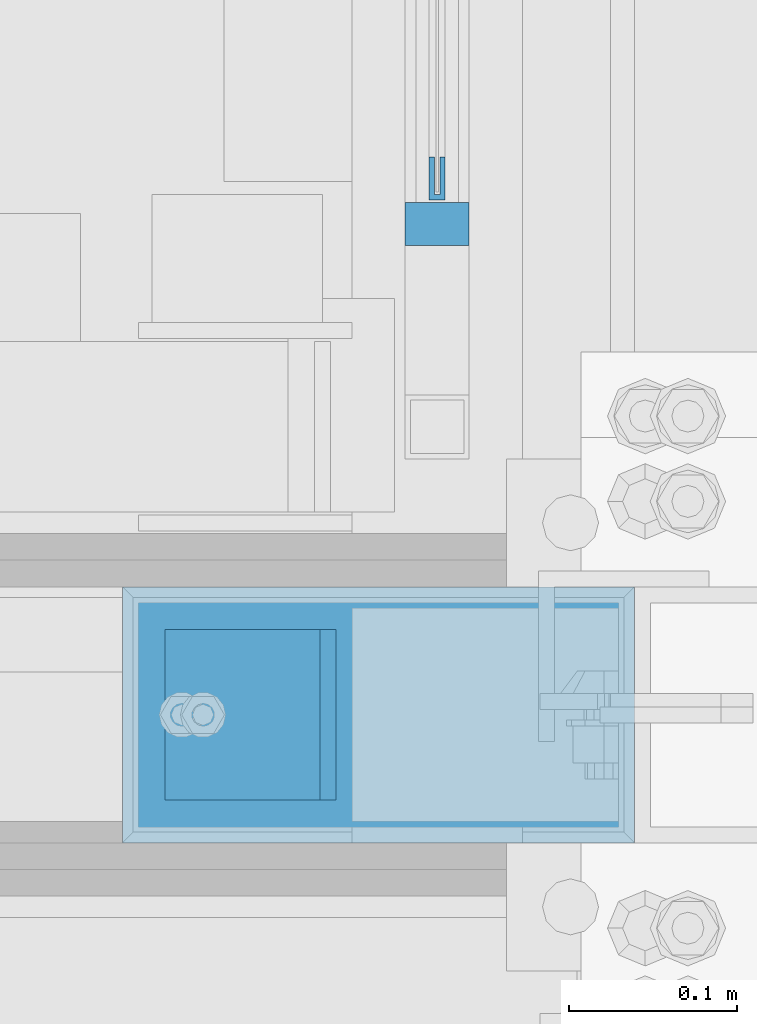
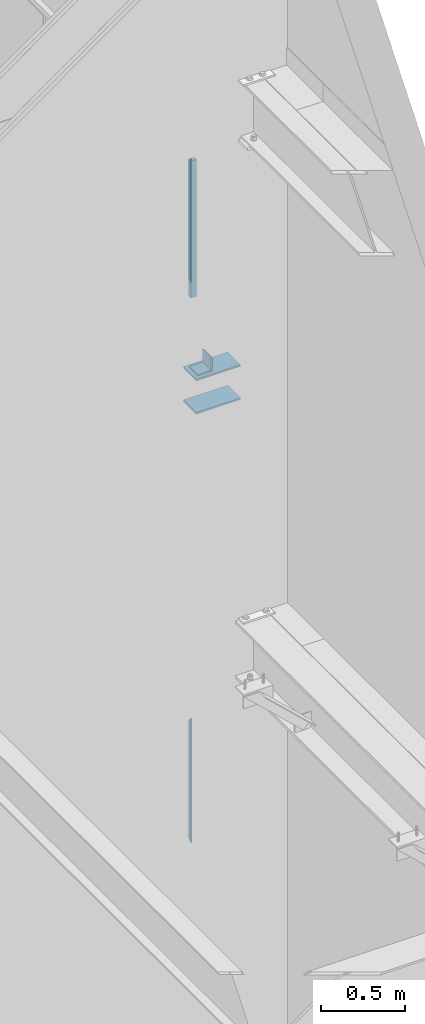
# One storey, part 919 of 1179: 5 beams, 1 member, 3 elements without a shape of their own.
"""IFC2X3 building model written with IfcOpenShell, lengths in millimetres."""

from ifc_helpers import new_model, si_unit, frame, origin_with_axes, place, context, subcontext, project, spatial, faceted_brep, material, type_object, element, aggregate, save


model = new_model("IFC2X3")

# Units and contexts
model_context = context("Model", 3, precision=1e-05, world=origin_with_axes())
body_context = subcontext(model_context, "Body", "Model", "MODEL_VIEW")
ifc_project = project(units=[si_unit("LENGTHUNIT", "METRE", prefix="MILLI"), si_unit("AREAUNIT", "SQUARE_METRE"), si_unit("VOLUMEUNIT", "CUBIC_METRE"), si_unit("MASSUNIT", "GRAM", prefix="KILO"), si_unit("TIMEUNIT", "SECOND"), si_unit("PLANEANGLEUNIT", "RADIAN"), si_unit("SOLIDANGLEUNIT", "STERADIAN"), si_unit("THERMODYNAMICTEMPERATUREUNIT", "DEGREE_CELSIUS"), si_unit("LUMINOUSINTENSITYUNIT", "LUMEN")], contexts=[model_context])

# Site, building, storey
site_placement = place(None, origin_with_axes())
site = spatial("IfcSite", under=ifc_project, at=site_placement, CompositionType="ELEMENT")
building_placement = place(site_placement, origin_with_axes())
building = spatial("IfcBuilding", under=site, at=building_placement, Name="Undefined", CompositionType="ELEMENT")
storey_placement = place(building_placement, origin_with_axes())
storey = spatial("IfcBuildingStorey", under=building, at=storey_placement, Name="Undefined", CompositionType="ELEMENT", Elevation=0.0)

# Assembly, member, beam
assembly_1_placement = place(storey_placement, origin_with_axes())
assembly_1 = element("IfcElementAssembly", 1, at=assembly_1_placement, inside=storey, Name="GUARDRAIL", AssemblyPlace="NOTDEFINED", PredefinedType="RIGID_FRAME")
ifc_material_1 = material(Name="STEEL/A36")
member_type = type_object("IfcMemberType", PredefinedType="NOTDEFINED")
member_placement = place(assembly_1_placement, frame((24114.1250004143, 38277.800000001, 6242.05), z_axis=(-1.0, 0.0, 0.0), x_axis=(0.0, 0.0, 1.0)))
member = element("IfcMember", 2, at=member_placement, type_object=member_type, material=ifc_material_1, Name="POST", context=body_context, shape_type="Brep", body=[
    faceted_brep([(0.0, 12.7000000000007, -19.0500000000029), (0.0, 12.7000000000007, 19.0500000000029), (996.950000401505, 12.6999999999971, 19.0499999999993), (996.950000401505, 12.6999999999971, -19.0499999999993), (0.0, -12.7000000000007, 19.0500000000029), (996.950000401505, -12.6999999999971, 19.0499999999993), (0.0, -12.7000000000007, -19.0500000000029), (996.950000401505, -12.6999999999971, -19.0499999999993)], [[[0, 1, 2, 3]], [[1, 4, 5, 2]], [[4, 6, 7, 5]], [[6, 0, 3, 7]], [[5, 7, 3, 2]], [[6, 4, 1, 0]]]),
])
ifc_material_2 = material(Name="STEEL/BUY-OUT")
beam_type_1 = type_object("IfcBeamType", PredefinedType="NOTDEFINED")
beam_1_placement = place(assembly_1_placement, frame((24110.9500703529, 38317.6192908844, 6784.97499993611), z_axis=(0.0, 0.0, 1.0), x_axis=(0.0, -1.0, 0.0)))
beam_1 = element("IfcBeam", 3, at=beam_1_placement, type_object=beam_type_1, material=ifc_material_2, Name="U-EDGE", context=body_context, shape_type="Brep", body=[
    faceted_brep([(0.0, 1.58750000000146, -427.037571475466), (22.2249999999985, 1.58750000000146, -449.262071101228), (22.2249999999985, 4.76249999999709, -449.262071101228), (0.0, 4.76249999999709, -427.037571475466), (0.0, 7.9375, -427.037571475466), (25.4000000000015, 7.9375, -452.4375), (25.4000000000015, -1.58750000000146, -452.4375), (0.0, -1.58750000000146, -427.037571475466), (25.4000000000015, -1.58750000000146, 452.4375), (0.0, -1.58750000000146, 427.037500076054), (0.0, 1.58750000000146, 427.037500076054), (22.2249999999985, 1.58750000000146, 449.262500000033), (22.2249999999985, 4.76249999999709, 449.262500000033), (0.0, 4.76249999999709, 427.037500000033), (0.0, 7.9375, 427.037500000033), (25.4000000000015, 7.9375, 452.4375)], [[[0, 1, 2, 3, 4, 5, 6, 7]], [[7, 6, 8, 9]], [[0, 7, 9, 10]], [[1, 0, 10, 11]], [[2, 1, 11, 12]], [[3, 2, 12, 13]], [[4, 3, 13, 14]], [[5, 4, 14, 15]], [[6, 5, 15, 8]], [[14, 13, 12, 11, 10, 9, 8, 15]]]),
])
aggregate(assembly_1, [beam_1, member])

# Assembly, beam
assembly_2_placement = place(storey_placement, origin_with_axes())
assembly_2 = element("IfcElementAssembly", 4, at=assembly_2_placement, inside=storey, Name="GUARDRAIL", AssemblyPlace="NOTDEFINED", PredefinedType="RIGID_FRAME")
beam_2_placement = place(assembly_2_placement, frame((24110.9500703529, 38317.6192908844, 2711.44999993611), z_axis=(0.0, 0.0, 1.0), x_axis=(0.0, -1.0, 0.0)))
beam_2 = element("IfcBeam", 5, at=beam_2_placement, type_object=beam_type_1, material=ifc_material_2, Name="U-EDGE", context=body_context, shape_type="Brep", body=[
    faceted_brep([(0.0, 1.58750000000146, -427.037571475466), (22.2249999999985, 1.58750000000146, -449.262071101228), (22.2249999999985, 4.76249999999709, -449.262071101228), (0.0, 4.76249999999709, -427.037571475466), (0.0, 7.9375, -427.037571475466), (25.4000000000015, 7.9375, -452.4375), (25.4000000000015, -1.58750000000146, -452.4375), (0.0, -1.58750000000146, -427.037571475466), (25.4000000000015, -1.58750000000146, 452.4375), (0.0, -1.58750000000146, 427.037500076054), (0.0, 1.58750000000146, 427.037500076054), (22.2249999999985, 1.58750000000146, 449.262500000033), (22.2249999999985, 4.76249999999709, 449.262500000033), (0.0, 4.76249999999709, 427.037500000033), (0.0, 7.9375, 427.037500000033), (25.4000000000015, 7.9375, 452.4375)], [[[0, 1, 2, 3, 4, 5, 6, 7]], [[7, 6, 8, 9]], [[0, 7, 9, 10]], [[1, 0, 10, 11]], [[2, 1, 11, 12]], [[3, 2, 12, 13]], [[4, 3, 13, 14]], [[5, 4, 14, 15]], [[6, 5, 15, 8]], [[14, 13, 12, 11, 10, 9, 8, 15]]]),
])
aggregate(assembly_2, [beam_2])

# Assembly, beams
assembly_3_placement = place(storey_placement, origin_with_axes())
assembly_3 = element("IfcElementAssembly", 6, at=assembly_3_placement, inside=storey, Name="COLUMN", AssemblyPlace="NOTDEFINED", PredefinedType="RIGID_FRAME")
beam_type_2 = type_object("IfcBeamType", Name="L4X4X3/8", PredefinedType="NOTDEFINED")
beam_3_placement = place(assembly_3_placement, frame((24002.9999995841, 37934.9, 5976.93749961063), z_axis=(-1.0, 0.0, 0.0), x_axis=(0.0, 1.0, 0.0)))
beam_3 = element("IfcBeam", 7, at=beam_3_placement, type_object=beam_type_2, material=ifc_material_1, Name="ANGLE", ObjectType="L4X4X3/8", context=body_context, shape_type="Brep", body=[
    faceted_brep([(1.90993887372315e-11, 50.8000000000002, -50.8000000000002), (1.90993887372315e-11, 50.8000000000002, 50.8000000000002), (101.599999999991, 50.7999999999993, 50.8000000000029), (101.599999999991, 50.7999999999993, -50.8000000000029), (0.0, 41.2750000000015, 50.8000000000029), (101.599999999991, 41.2750000000015, 50.8000000000029), (0.0, 41.2750000000015, -41.2750000000015), (101.599999999991, 41.2750000000015, -41.2750000000015), (0.0, -50.7999999999993, -41.2750000000015), (101.599999999991, -50.7999999999993, -41.2750000000015), (-1.81898940354586e-11, -50.7999999999997, -50.8000000000002), (101.599999999991, -50.7999999999993, -50.8000000000029)], [[[0, 1, 2, 3]], [[1, 4, 5, 2]], [[4, 6, 7, 5]], [[6, 8, 9, 7]], [[8, 10, 11, 9]], [[10, 0, 3, 11]], [[5, 7, 9, 11, 3, 2]], [[10, 8, 6, 4, 1, 0]]]),
])
beam_type_3 = type_object("IfcBeamType", PredefinedType="NOTDEFINED")
beam_4_placement = place(assembly_3_placement, frame((24231.6000004119, 37985.7, 5919.78749930242), z_axis=(0.0, 1.0, 0.0), x_axis=(-1.0, 0.0, 0.0)))
beam_4 = element("IfcBeam", 8, at=beam_4_placement, type_object=beam_type_3, material=ifc_material_1, Name="PLATE", context=body_context, shape_type="Brep", body=[
    faceted_brep([(-7.27595761418343e-12, 6.35000000000036, -76.1999999999971), (0.0, 6.35000000000036, 76.2000000000044), (304.799999999996, 6.349999999994, 76.1999999999971), (304.799999999996, 6.349999999994, -76.1999999999971), (0.0, -6.35000000000036, 76.2000000000044), (304.80000000001, -6.35000000000582, 76.1999999999971), (7.27595761418343e-12, -6.35000000000036, -76.1999999999971), (304.80000000001, -6.35000000000582, -76.1999999999971)], [[[0, 1, 2, 3]], [[1, 4, 5, 2]], [[4, 6, 7, 5]], [[6, 0, 3, 7]], [[5, 7, 3, 2]], [[6, 4, 1, 0]]]),
])
beam_5_placement = place(assembly_3_placement, frame((24231.5999999295, 37985.7, 5678.48749930242), z_axis=(0.0, -1.0, 0.0), x_axis=(-1.0, 0.0, 0.0)))
beam_5 = element("IfcBeam", 9, at=beam_5_placement, type_object=beam_type_3, material=ifc_material_1, Name="PLATE", context=body_context, shape_type="Brep", body=[
    faceted_brep([(-7.27595761418343e-12, 6.35000000000036, -76.1999999999971), (0.0, 6.35000000000036, 76.2000000000044), (304.799999999996, 6.349999999994, 76.1999999999971), (304.799999999996, 6.349999999994, -76.1999999999971), (0.0, -6.35000000000036, 76.2000000000044), (304.80000000001, -6.35000000000582, 76.1999999999971), (7.27595761418343e-12, -6.35000000000036, -76.1999999999971), (304.80000000001, -6.35000000000582, -76.1999999999971)], [[[0, 1, 2, 3]], [[1, 4, 5, 2]], [[4, 6, 7, 5]], [[6, 0, 3, 7]], [[5, 7, 3, 2]], [[6, 4, 1, 0]]]),
])
aggregate(assembly_3, [beam_3, beam_4, beam_5])

save(model, "model.ifc")
